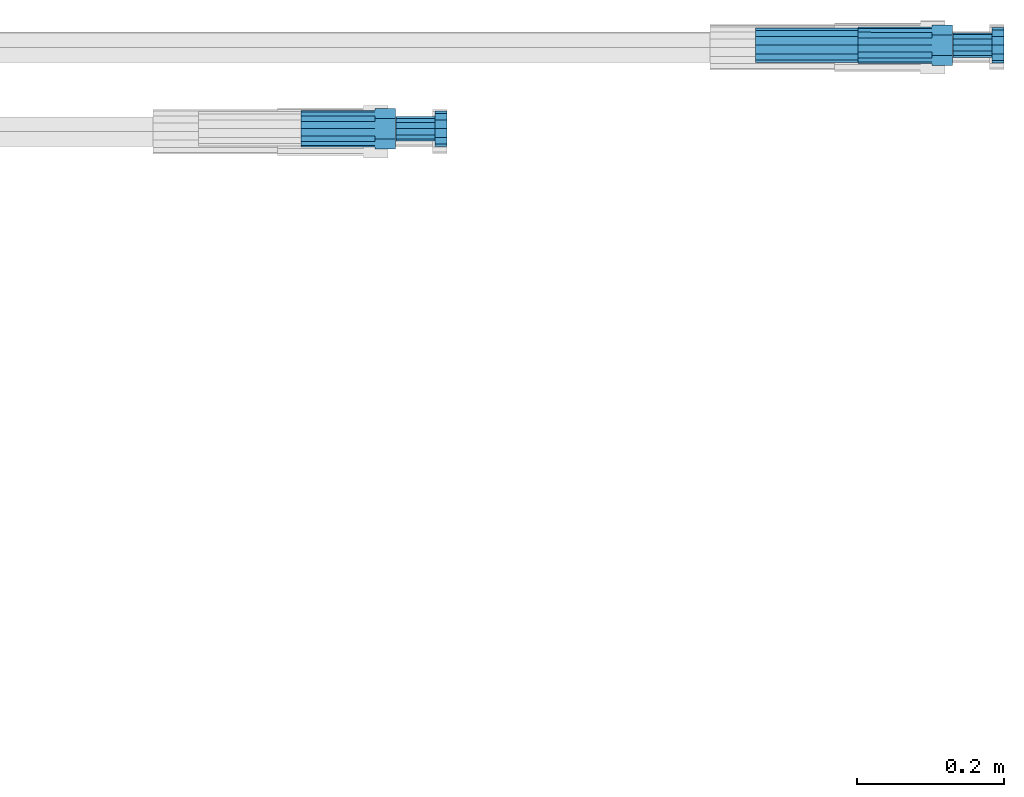
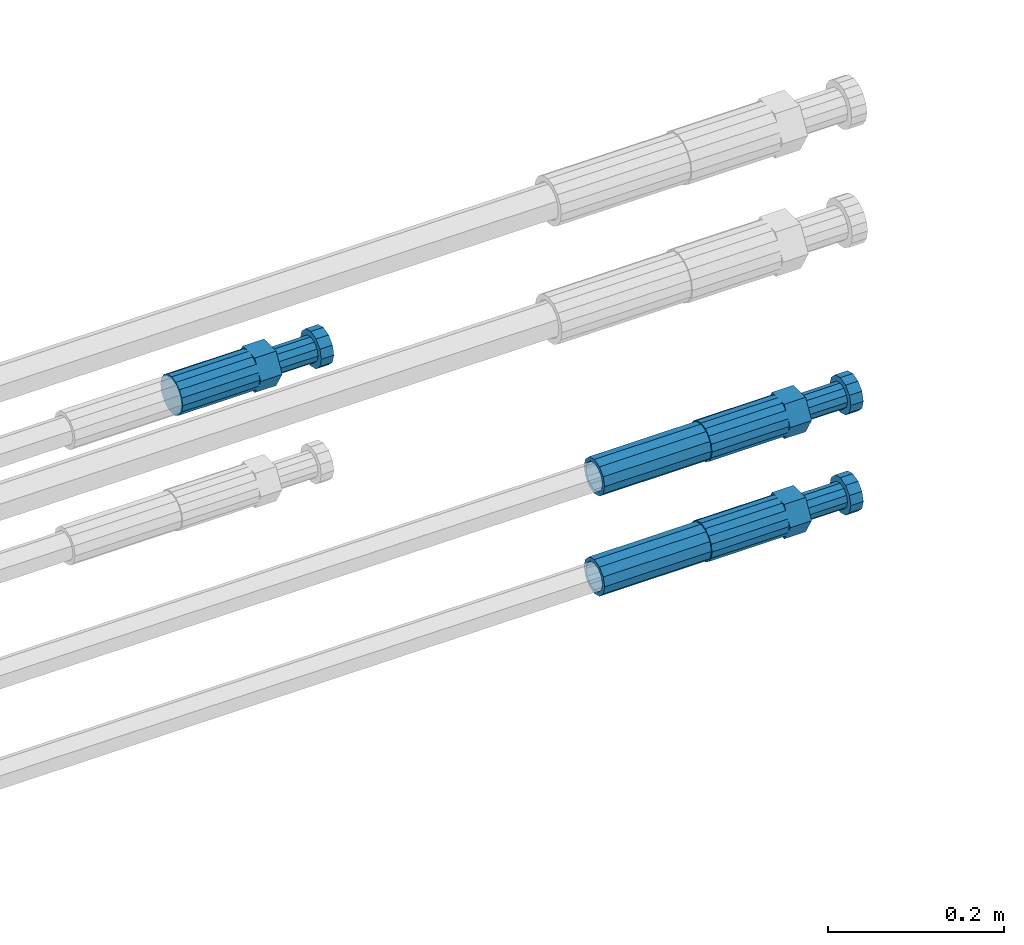
# One storey, part 110 of 119: 5 beams.
"""IFC2X3 building model written with IfcOpenShell, lengths in millimetres."""

from ifc_helpers import new_model, si_unit, frame, origin_with_axes, place, context, subcontext, project, spatial, faceted_brep, material, type_object, element, save


model = new_model("IFC2X3")

# Units and contexts
model_context = context("Model", 3, precision=1e-05, world=origin_with_axes())
body_context = subcontext(model_context, "Body", "Model", "MODEL_VIEW")
ifc_project = project(units=[si_unit("LENGTHUNIT", "METRE", prefix="MILLI"), si_unit("AREAUNIT", "SQUARE_METRE"), si_unit("VOLUMEUNIT", "CUBIC_METRE"), si_unit("MASSUNIT", "GRAM", prefix="KILO"), si_unit("TIMEUNIT", "SECOND"), si_unit("PLANEANGLEUNIT", "RADIAN"), si_unit("SOLIDANGLEUNIT", "STERADIAN"), si_unit("THERMODYNAMICTEMPERATUREUNIT", "DEGREE_CELSIUS"), si_unit("LUMINOUSINTENSITYUNIT", "LUMEN")], contexts=[model_context])

# Site, building, storey
site_placement = place(None, origin_with_axes())
site = spatial("IfcSite", under=ifc_project, at=site_placement, CompositionType="ELEMENT")
building_placement = place(site_placement, origin_with_axes())
building = spatial("IfcBuilding", under=site, at=building_placement, Name="Undefined", CompositionType="ELEMENT")
storey_placement = place(building_placement, origin_with_axes())
storey = spatial("IfcBuildingStorey", under=building, at=storey_placement, Name="Undefined", CompositionType="ELEMENT", Elevation=0.0)

# Beams
ifc_material = material(Name="STEEL/S275")
beam_type_1 = type_object("IfcBeamType", PredefinedType="NOTDEFINED")
beam_1_placement = place(storey_placement, frame((2039411.00023304, 6206403.47994599, 18871.489412972), z_axis=(0.0, 0.0, 1.0), x_axis=(1.0, 0.0, 0.0)))
element("IfcBeam", 1, at=beam_1_placement, inside=storey, type_object=beam_type_1, material=ifc_material, Name="AG32N", context=body_context, shape_type="Brep", body=[
    faceted_brep([(1.39698386192322e-09, -18.4999999990687, 0.0), (1.16415321826935e-09, -16.0214699693024, 9.25), (140.000000001164, -16.0214699935168, 9.25), (140.000000001397, -18.5000000232831, 0.0), (6.98491930961609e-10, -9.24999999906868, 16.0214699700118), (140.000000000698, -9.25000002328306, 16.0214699700118), (2.3283064365387e-10, 9.31322574615479e-10, 18.5), (140.000000000233, -2.3283064365387e-08, 18.5), (-2.3283064365387e-10, 9.25000000093132, 16.0214699700118), (139.999999999767, 9.24999997671694, 16.0214699700118), (-6.98491930961609e-10, 16.0214699711651, 9.25), (139.999999999302, 16.0214699469507, 9.25), (-9.31322574615479e-10, 18.5000000009313, 0.0), (139.999999999069, 18.4999999767169, 0.0), (-6.98491930961609e-10, 16.0214699711651, -9.25), (139.999999999302, 16.0214699469507, -9.25), (-2.3283064365387e-10, 9.25000000093132, -16.0214699700118), (139.999999999767, 9.24999997671694, -16.0214699700118), (2.3283064365387e-10, 9.31322574615479e-10, -18.5), (140.000000000233, -2.3283064365387e-08, -18.5), (6.98491930961609e-10, -9.24999999906868, -16.0214699700118), (140.000000000698, -9.25000002328306, -16.0214699700118), (1.16415321826935e-09, -16.0214699693024, -9.25), (140.000000001164, -16.0214699935168, -9.25), (1.62981450557709e-09, -23.4999999990687, 0.0), (1.39698386192322e-09, -20.3515969878063, -11.75), (140.000000001397, -20.3515970120206, -11.75), (140.00000000163, -23.5000000232831, 0.0), (9.31322574615479e-10, -11.7499999990687, -20.351596988934), (140.000000000931, -11.7500000232831, -20.351596988934), (2.3283064365387e-10, 9.31322574615479e-10, -23.5), (140.000000000233, -2.3283064365387e-08, -23.5), (-4.65661287307739e-10, 11.7500000009313, -20.351596988934), (139.999999999534, 11.7499999767169, -20.351596988934), (-9.31322574615479e-10, 20.3515969896689, -11.75), (139.999999999069, 20.3515969654545, -11.75), (-1.16415321826935e-09, 23.5000000009313, 0.0), (139.999999998836, 23.4999999767169, 0.0), (-9.31322574615479e-10, 20.3515969896689, 11.75), (139.999999999069, 20.3515969654545, 11.75), (-4.65661287307739e-10, 11.7500000009313, 20.351596988934), (139.999999999534, 11.7499999767169, 20.351596988934), (2.3283064365387e-10, 9.31322574615479e-10, 23.5), (140.000000000233, -2.3283064365387e-08, 23.5), (9.31322574615479e-10, -11.7499999990687, 20.351596988934), (140.000000000931, -11.7500000232831, 20.351596988934), (1.39698386192322e-09, -20.3515969878063, 11.75), (140.000000001397, -20.3515970120206, 11.75)], [[[0, 1, 2, 3]], [[1, 4, 5, 2]], [[4, 6, 7, 5]], [[6, 8, 9, 7]], [[8, 10, 11, 9]], [[10, 12, 13, 11]], [[12, 14, 15, 13]], [[14, 16, 17, 15]], [[16, 18, 19, 17]], [[18, 20, 21, 19]], [[20, 22, 23, 21]], [[22, 0, 3, 23]], [[24, 25, 26, 27]], [[25, 28, 29, 26]], [[28, 30, 31, 29]], [[30, 32, 33, 31]], [[32, 34, 35, 33]], [[34, 36, 37, 35]], [[36, 38, 39, 37]], [[38, 40, 41, 39]], [[40, 42, 43, 41]], [[42, 44, 45, 43]], [[44, 46, 47, 45]], [[46, 24, 27, 47]], [[29, 31, 33, 35, 37, 39, 41, 43, 45, 47, 27, 26], [5, 7, 9, 11, 13, 15, 17, 19, 21, 23, 3, 2]], [[46, 44, 42, 40, 38, 36, 34, 32, 30, 28, 25, 24], [22, 20, 18, 16, 14, 12, 10, 8, 6, 4, 1, 0]]]),
])
beam_2_placement = place(storey_placement, frame((2039411.00023304, 6206403.47994599, 19010.269412972), z_axis=(0.0, 0.0, 1.0), x_axis=(1.0, 0.0, 0.0)))
element("IfcBeam", 2, at=beam_2_placement, inside=storey, type_object=beam_type_1, material=ifc_material, Name="AG32N", context=body_context, shape_type="Brep", body=[
    faceted_brep([(1.39698386192322e-09, -18.4999999990687, 0.0), (1.16415321826935e-09, -16.0214699693024, 9.25), (140.000000001164, -16.0214699935168, 9.25), (140.000000001397, -18.5000000232831, 0.0), (6.98491930961609e-10, -9.24999999906868, 16.0214699700118), (140.000000000698, -9.25000002328306, 16.0214699700118), (2.3283064365387e-10, 9.31322574615479e-10, 18.5), (140.000000000233, -2.3283064365387e-08, 18.5), (-2.3283064365387e-10, 9.25000000093132, 16.0214699700118), (139.999999999767, 9.24999997671694, 16.0214699700118), (-6.98491930961609e-10, 16.0214699711651, 9.25), (139.999999999302, 16.0214699469507, 9.25), (-9.31322574615479e-10, 18.5000000009313, 0.0), (139.999999999069, 18.4999999767169, 0.0), (-6.98491930961609e-10, 16.0214699711651, -9.25), (139.999999999302, 16.0214699469507, -9.25), (-2.3283064365387e-10, 9.25000000093132, -16.0214699700118), (139.999999999767, 9.24999997671694, -16.0214699700118), (2.3283064365387e-10, 9.31322574615479e-10, -18.5), (140.000000000233, -2.3283064365387e-08, -18.5), (6.98491930961609e-10, -9.24999999906868, -16.0214699700118), (140.000000000698, -9.25000002328306, -16.0214699700118), (1.16415321826935e-09, -16.0214699693024, -9.25), (140.000000001164, -16.0214699935168, -9.25), (1.62981450557709e-09, -23.4999999990687, 0.0), (1.39698386192322e-09, -20.3515969878063, -11.75), (140.000000001397, -20.3515970120206, -11.75), (140.00000000163, -23.5000000232831, 0.0), (9.31322574615479e-10, -11.7499999990687, -20.351596988934), (140.000000000931, -11.7500000232831, -20.351596988934), (2.3283064365387e-10, 9.31322574615479e-10, -23.5), (140.000000000233, -2.3283064365387e-08, -23.5), (-4.65661287307739e-10, 11.7500000009313, -20.351596988934), (139.999999999534, 11.7499999767169, -20.351596988934), (-9.31322574615479e-10, 20.3515969896689, -11.75), (139.999999999069, 20.3515969654545, -11.75), (-1.16415321826935e-09, 23.5000000009313, 0.0), (139.999999998836, 23.4999999767169, 0.0), (-9.31322574615479e-10, 20.3515969896689, 11.75), (139.999999999069, 20.3515969654545, 11.75), (-4.65661287307739e-10, 11.7500000009313, 20.351596988934), (139.999999999534, 11.7499999767169, 20.351596988934), (2.3283064365387e-10, 9.31322574615479e-10, 23.5), (140.000000000233, -2.3283064365387e-08, 23.5), (9.31322574615479e-10, -11.7499999990687, 20.351596988934), (140.000000000931, -11.7500000232831, 20.351596988934), (1.39698386192322e-09, -20.3515969878063, 11.75), (140.000000001397, -20.3515970120206, 11.75)], [[[0, 1, 2, 3]], [[1, 4, 5, 2]], [[4, 6, 7, 5]], [[6, 8, 9, 7]], [[8, 10, 11, 9]], [[10, 12, 13, 11]], [[12, 14, 15, 13]], [[14, 16, 17, 15]], [[16, 18, 19, 17]], [[18, 20, 21, 19]], [[20, 22, 23, 21]], [[22, 0, 3, 23]], [[24, 25, 26, 27]], [[25, 28, 29, 26]], [[28, 30, 31, 29]], [[30, 32, 33, 31]], [[32, 34, 35, 33]], [[34, 36, 37, 35]], [[36, 38, 39, 37]], [[38, 40, 41, 39]], [[40, 42, 43, 41]], [[42, 44, 45, 43]], [[44, 46, 47, 45]], [[46, 24, 27, 47]], [[29, 31, 33, 35, 37, 39, 41, 43, 45, 47, 27, 26], [5, 7, 9, 11, 13, 15, 17, 19, 21, 23, 3, 2]], [[46, 44, 42, 40, 38, 36, 34, 32, 30, 28, 25, 24], [22, 20, 18, 16, 14, 12, 10, 8, 6, 4, 1, 0]]]),
])
beam_type_2 = type_object("IfcBeamType", Name="ROD50", PredefinedType="NOTDEFINED")
beam_3_placement = place(storey_placement, frame((2038791.00023304, 6206289.47994599, 19409.489419125), z_axis=(0.0, 0.0, 1.0), x_axis=(1.0, 0.0, 0.0)))
element("IfcBeam", 3, at=beam_3_placement, inside=storey, type_object=beam_type_2, material=ifc_material, Name="AGB32", ObjectType="ROD50", context=body_context, shape_type="Brep", body=[
    faceted_brep([(100.999999995111, 13.8425000002608, 23.9759132212093), (100.999999996508, 17.5285119004548, 17.5915533324223), (100.999999997672, 9.56708580907434, 23.0969883129546), (100.999999995111, 5.14843190740794, 23.9759132212093), (100.999999995111, -13.8425000002608, 23.9759132212093), (129.099999995669, -13.8425000002608, 23.9759132182917), (129.099999995669, 13.8425000002608, 23.9759132182917), (100.999999995111, -5.14843190740794, 23.9759132212093), (100.999999996508, -17.5285119004548, 17.5915533324223), (100.999999997672, -9.56708580907434, 23.0969883129546), (101.000000000233, -27.6849999995902, -8.25639290269464e-08), (129.100000000792, -27.6849999995902, -8.5481588030234e-08), (100.999999998836, -23.5887256683782, 7.09495518143376), (101.00000000163, -23.5887256180868, -7.09495543353478), (101.000000000233, -25.0, 1.70985003933311e-10), (101.000000005355, -13.8425000002608, -23.9759133863372), (129.100000005914, -13.8425000002608, -23.9759133892549), (101.000000003958, -17.5285119721666, -17.5915533734478), (101.000000005355, -5.14843107573688, -23.9759133863372), (101.000000002561, -9.56708580907434, -23.0969883126127), (101.000000005355, 13.8425000002608, -23.9759133863372), (129.100000005914, 13.8425000002608, -23.9759133892549), (101.000000005355, 5.14843107573688, -23.9759133863372), (101.000000002561, 9.56708580907434, -23.0969883126127), (101.000000003958, 17.5285119721666, -17.5915533734478), (101.000000000233, 27.6849999995902, -8.25639290269464e-08), (129.100000000792, 27.6849999995902, -8.5481588030234e-08), (101.00000000163, 23.5887256180868, -7.09495543353478), (101.000000000233, 25.0, 1.70985003933311e-10), (100.999999998836, 23.5887256683782, 7.09495518143376), (-6.98491930961609e-10, -23.0969883129001, 9.56708580912891), (-1.62981450557709e-09, -17.6776695298031, 17.6776695296649), (-2.3283064365387e-09, -9.56708580907434, 23.0969883127837), (-2.56113708019257e-09, 0.0, 25.0), (-2.3283064365387e-09, 9.56708580907434, 23.0969883127837), (-1.62981450557709e-09, 17.6776695298031, 17.6776695296649), (-6.98491930961609e-10, 23.0969883129001, 9.56708580912891), (2.3283064365387e-10, 25.0, 0.0), (1.16415321826935e-09, 23.0969883129001, -9.56708580912891), (2.09547579288483e-09, 17.6776695298031, -17.6776695296649), (2.56113708019257e-09, 9.56708580907434, -23.0969883127837), (2.79396772384644e-09, 0.0, -25.0), (2.56113708019257e-09, -9.56708580907434, -23.0969883127837), (2.09547579288483e-09, -17.6776695298031, -17.6776695296649), (1.16415321826935e-09, -23.0969883129001, -9.56708580912891), (2.3283064365387e-10, -25.0, 0.0), (100.999999999302, 23.0969883129001, 9.5670858092999), (101.000000001164, 23.0969883129001, -9.56708580895793), (101.000000002794, 0.0, -24.999999999829), (101.000000001164, -23.0969883129001, -9.56708580895793), (100.999999999302, -23.0969883129001, 9.5670858092999), (100.999999997439, 0.0, 25.000000000171), (129.49999999837, -14.2894191620871, 8.24999989414209), (129.499999996973, -8.25, 14.2894190565821), (129.49999999674, 0.0, 16.4999998941421), (129.499999996973, 8.25, 14.2894190565821), (129.49999999837, 14.2894191620871, 8.24999989414209), (129.500000000233, 16.5, -1.05857907328755e-07), (129.500000002095, 14.2894191620871, -8.25000010585791), (129.50000000326, 8.25, -14.2894192683016), (129.500000003492, 0.0, -16.5000001058615), (129.50000000326, -8.25, -14.2894192683016), (129.500000002095, -14.2894191620871, -8.25000010586155), (129.500000000233, -16.5, -1.05857907328755e-07), (182.499999996973, 8.25, 14.2894190510815), (182.49999999674, 0.0, 16.4999998886415), (182.49999999837, 14.2894191620871, 8.24999988864147), (182.500000000233, 16.5, -1.11358531285077e-07), (182.500000002095, 14.2894191620871, -8.25000011135853), (182.50000000326, 8.25, -14.2894192738022), (182.500000003492, 0.0, -16.5000001113622), (182.50000000326, -8.25, -14.2894192738022), (182.500000002095, -14.2894191620871, -8.25000011136217), (182.500000000233, -16.5, -1.11358531285077e-07), (182.49999999837, -14.2894191620871, 8.24999988864147), (182.499999996973, -8.25, 14.2894190510815), (182.500000002561, -20.7846096912399, -12.0000001491826), (182.500000004657, -12.0, -20.7846098400078), (199.000000004657, -12.0, -20.7846098417212), (199.000000002561, -20.7846096912399, -12.0000001508961), (182.500000005355, 0.0, -24.0000001491826), (199.000000005355, 0.0, -24.0000001508961), (182.500000004657, 12.0, -20.7846098400078), (199.000000004657, 12.0, -20.7846098417212), (182.500000002561, 20.7846096912399, -12.000000149179), (199.000000002561, 20.7846096912399, -12.0000001508924), (182.500000000233, 24.0, -1.49178958963603e-07), (199.000000000233, 24.0, -1.50892446981743e-07), (182.499999997672, 20.7846096912399, 11.999999850821), (198.999999997672, 20.7846096912399, 11.9999998491076), (182.499999995809, 12.0, 20.7846095416462), (198.999999995809, 12.0, 20.7846095399327), (182.499999995111, 0.0, 23.999999850821), (198.999999995111, 0.0, 23.9999998491076), (182.499999995809, -12.0, 20.7846095416462), (198.999999995809, -12.0, 20.7846095399327), (182.499999997672, -20.7846096912399, 11.999999850821), (198.999999997672, -20.7846096912399, 11.9999998491039), (182.500000000233, -24.0, -1.49178958963603e-07), (199.000000000233, -24.0, -1.50892446981743e-07)], [[[0, 1, 2, 3]], [[4, 5, 6, 0, 3, 7]], [[8, 4, 7, 9]], [[10, 11, 5, 4, 8, 12]], [[13, 10, 12, 14]], [[15, 16, 11, 10, 13, 17]], [[18, 15, 17, 19]], [[20, 21, 16, 15, 18, 22]], [[20, 22, 23, 24]], [[25, 26, 21, 20, 24, 27]], [[25, 27, 28, 29]], [[30, 31, 32, 33, 34, 35, 36, 37, 38, 39, 40, 41, 42, 43, 44, 45]], [[28, 37, 36, 46, 29]], [[27, 47, 38, 37, 28]], [[24, 47, 27]], [[39, 38, 47, 24]], [[23, 40, 39, 24]], [[22, 48, 41, 40, 23]], [[18, 48, 22]], [[19, 42, 41, 48, 18]], [[17, 43, 42, 19]], [[44, 43, 17, 49]], [[13, 49, 17]], [[14, 45, 44, 49, 13]], [[12, 50, 30, 45, 14]], [[8, 50, 12]], [[31, 30, 50, 8]], [[9, 32, 31, 8]], [[7, 51, 33, 32, 9]], [[3, 51, 7]], [[2, 34, 33, 51, 3]], [[1, 35, 34, 2]], [[36, 35, 1, 46]], [[29, 46, 1]], [[0, 6, 26, 25, 29, 1]], [[5, 11, 16, 21, 26, 6]], [[52, 53, 54, 55, 56, 57, 58, 59, 60, 61, 62, 63]], [[64, 55, 54, 65]], [[66, 56, 55, 64]], [[67, 57, 56, 66]], [[68, 58, 57, 67]], [[69, 59, 58, 68]], [[70, 60, 59, 69]], [[71, 61, 60, 70]], [[72, 62, 61, 71]], [[73, 63, 62, 72]], [[74, 52, 63, 73]], [[75, 53, 52, 74]], [[65, 54, 53, 75]], [[76, 77, 78, 79]], [[77, 80, 81, 78]], [[80, 82, 83, 81]], [[82, 84, 85, 83]], [[84, 86, 87, 85]], [[86, 88, 89, 87]], [[88, 90, 91, 89]], [[90, 92, 93, 91]], [[92, 94, 95, 93]], [[94, 96, 97, 95]], [[96, 98, 99, 97]], [[78, 81, 83, 85, 87, 89, 91, 93, 95, 97, 99, 79]], [[98, 76, 79, 99]], [[96, 94, 92, 90, 88, 86, 84, 82, 80, 77, 76, 98], [74, 73, 72, 71, 70, 69, 68, 67, 66, 64, 65, 75]]]),
])
beam_4_placement = place(storey_placement, frame((2039551.00023304, 6206403.47994599, 18871.4894149922), z_axis=(0.0, 0.0, 1.0), x_axis=(1.0, 0.0, 0.0)))
element("IfcBeam", 4, at=beam_4_placement, inside=storey, type_object=beam_type_2, material=ifc_material, Name="AGB32", ObjectType="ROD50", context=body_context, shape_type="Brep", body=[
    faceted_brep([(100.999999995111, 13.8425000002608, 23.9759132212093), (100.999999996508, 17.5285119004548, 17.5915533324223), (100.999999997672, 9.56708580907434, 23.0969883129546), (100.999999995111, 5.14843190740794, 23.9759132212093), (100.999999995111, -13.8425000002608, 23.9759132212093), (129.099999995669, -13.8425000002608, 23.9759132182917), (129.099999995669, 13.8425000002608, 23.9759132182917), (100.999999995111, -5.14843190740794, 23.9759132212093), (100.999999996508, -17.5285119004548, 17.5915533324223), (100.999999997672, -9.56708580907434, 23.0969883129546), (101.000000000233, -27.6849999995902, -8.25639290269464e-08), (129.100000000792, -27.6849999995902, -8.5481588030234e-08), (100.999999998836, -23.5887256683782, 7.09495518143376), (101.00000000163, -23.5887256180868, -7.09495543353478), (101.000000000233, -25.0, 1.70985003933311e-10), (101.000000005355, -13.8425000002608, -23.9759133863372), (129.100000005914, -13.8425000002608, -23.9759133892549), (101.000000003958, -17.5285119721666, -17.5915533734478), (101.000000005355, -5.14843107573688, -23.9759133863372), (101.000000002561, -9.56708580907434, -23.0969883126127), (101.000000005355, 13.8425000002608, -23.9759133863372), (129.100000005914, 13.8425000002608, -23.9759133892549), (101.000000005355, 5.14843107573688, -23.9759133863372), (101.000000002561, 9.56708580907434, -23.0969883126127), (101.000000003958, 17.5285119721666, -17.5915533734478), (101.000000000233, 27.6849999995902, -8.25639290269464e-08), (129.100000000792, 27.6849999995902, -8.5481588030234e-08), (101.00000000163, 23.5887256180868, -7.09495543353478), (101.000000000233, 25.0, 1.70985003933311e-10), (100.999999998836, 23.5887256683782, 7.09495518143376), (-6.98491930961609e-10, -23.0969883129001, 9.56708580912891), (-1.62981450557709e-09, -17.6776695298031, 17.6776695296649), (-2.3283064365387e-09, -9.56708580907434, 23.0969883127837), (-2.56113708019257e-09, 0.0, 25.0), (-2.3283064365387e-09, 9.56708580907434, 23.0969883127837), (-1.62981450557709e-09, 17.6776695298031, 17.6776695296649), (-6.98491930961609e-10, 23.0969883129001, 9.56708580912891), (2.3283064365387e-10, 25.0, 0.0), (1.16415321826935e-09, 23.0969883129001, -9.56708580912891), (2.09547579288483e-09, 17.6776695298031, -17.6776695296649), (2.56113708019257e-09, 9.56708580907434, -23.0969883127837), (2.79396772384644e-09, 0.0, -25.0), (2.56113708019257e-09, -9.56708580907434, -23.0969883127837), (2.09547579288483e-09, -17.6776695298031, -17.6776695296649), (1.16415321826935e-09, -23.0969883129001, -9.56708580912891), (2.3283064365387e-10, -25.0, 0.0), (100.999999999302, 23.0969883129001, 9.5670858092999), (101.000000001164, 23.0969883129001, -9.56708580895793), (101.000000002794, 0.0, -24.999999999829), (101.000000001164, -23.0969883129001, -9.56708580895793), (100.999999999302, -23.0969883129001, 9.5670858092999), (100.999999997439, 0.0, 25.000000000171), (129.49999999837, -14.2894191620871, 8.24999989414209), (129.499999996973, -8.25, 14.2894190565821), (129.49999999674, 0.0, 16.4999998941421), (129.499999996973, 8.25, 14.2894190565821), (129.49999999837, 14.2894191620871, 8.24999989414209), (129.500000000233, 16.5, -1.05857907328755e-07), (129.500000002095, 14.2894191620871, -8.25000010585791), (129.50000000326, 8.25, -14.2894192683016), (129.500000003492, 0.0, -16.5000001058615), (129.50000000326, -8.25, -14.2894192683016), (129.500000002095, -14.2894191620871, -8.25000010586155), (129.500000000233, -16.5, -1.05857907328755e-07), (182.499999996973, 8.25, 14.2894190510815), (182.49999999674, 0.0, 16.4999998886415), (182.49999999837, 14.2894191620871, 8.24999988864147), (182.500000000233, 16.5, -1.11358531285077e-07), (182.500000002095, 14.2894191620871, -8.25000011135853), (182.50000000326, 8.25, -14.2894192738022), (182.500000003492, 0.0, -16.5000001113622), (182.50000000326, -8.25, -14.2894192738022), (182.500000002095, -14.2894191620871, -8.25000011136217), (182.500000000233, -16.5, -1.11358531285077e-07), (182.49999999837, -14.2894191620871, 8.24999988864147), (182.499999996973, -8.25, 14.2894190510815), (182.500000002561, -20.7846096912399, -12.0000001491826), (182.500000004657, -12.0, -20.7846098400078), (199.000000004657, -12.0, -20.7846098417212), (199.000000002561, -20.7846096912399, -12.0000001508961), (182.500000005355, 0.0, -24.0000001491826), (199.000000005355, 0.0, -24.0000001508961), (182.500000004657, 12.0, -20.7846098400078), (199.000000004657, 12.0, -20.7846098417212), (182.500000002561, 20.7846096912399, -12.000000149179), (199.000000002561, 20.7846096912399, -12.0000001508924), (182.500000000233, 24.0, -1.49178958963603e-07), (199.000000000233, 24.0, -1.50892446981743e-07), (182.499999997672, 20.7846096912399, 11.999999850821), (198.999999997672, 20.7846096912399, 11.9999998491076), (182.499999995809, 12.0, 20.7846095416462), (198.999999995809, 12.0, 20.7846095399327), (182.499999995111, 0.0, 23.999999850821), (198.999999995111, 0.0, 23.9999998491076), (182.499999995809, -12.0, 20.7846095416462), (198.999999995809, -12.0, 20.7846095399327), (182.499999997672, -20.7846096912399, 11.999999850821), (198.999999997672, -20.7846096912399, 11.9999998491039), (182.500000000233, -24.0, -1.49178958963603e-07), (199.000000000233, -24.0, -1.50892446981743e-07)], [[[0, 1, 2, 3]], [[4, 5, 6, 0, 3, 7]], [[8, 4, 7, 9]], [[10, 11, 5, 4, 8, 12]], [[13, 10, 12, 14]], [[15, 16, 11, 10, 13, 17]], [[18, 15, 17, 19]], [[20, 21, 16, 15, 18, 22]], [[20, 22, 23, 24]], [[25, 26, 21, 20, 24, 27]], [[25, 27, 28, 29]], [[30, 31, 32, 33, 34, 35, 36, 37, 38, 39, 40, 41, 42, 43, 44, 45]], [[28, 37, 36, 46, 29]], [[27, 47, 38, 37, 28]], [[24, 47, 27]], [[39, 38, 47, 24]], [[23, 40, 39, 24]], [[22, 48, 41, 40, 23]], [[18, 48, 22]], [[19, 42, 41, 48, 18]], [[17, 43, 42, 19]], [[44, 43, 17, 49]], [[13, 49, 17]], [[14, 45, 44, 49, 13]], [[12, 50, 30, 45, 14]], [[8, 50, 12]], [[31, 30, 50, 8]], [[9, 32, 31, 8]], [[7, 51, 33, 32, 9]], [[3, 51, 7]], [[2, 34, 33, 51, 3]], [[1, 35, 34, 2]], [[36, 35, 1, 46]], [[29, 46, 1]], [[0, 6, 26, 25, 29, 1]], [[5, 11, 16, 21, 26, 6]], [[52, 53, 54, 55, 56, 57, 58, 59, 60, 61, 62, 63]], [[64, 55, 54, 65]], [[66, 56, 55, 64]], [[67, 57, 56, 66]], [[68, 58, 57, 67]], [[69, 59, 58, 68]], [[70, 60, 59, 69]], [[71, 61, 60, 70]], [[72, 62, 61, 71]], [[73, 63, 62, 72]], [[74, 52, 63, 73]], [[75, 53, 52, 74]], [[65, 54, 53, 75]], [[76, 77, 78, 79]], [[77, 80, 81, 78]], [[80, 82, 83, 81]], [[82, 84, 85, 83]], [[84, 86, 87, 85]], [[86, 88, 89, 87]], [[88, 90, 91, 89]], [[90, 92, 93, 91]], [[92, 94, 95, 93]], [[94, 96, 97, 95]], [[96, 98, 99, 97]], [[78, 81, 83, 85, 87, 89, 91, 93, 95, 97, 99, 79]], [[98, 76, 79, 99]], [[96, 94, 92, 90, 88, 86, 84, 82, 80, 77, 76, 98], [74, 73, 72, 71, 70, 69, 68, 67, 66, 64, 65, 75]]]),
])
beam_5_placement = place(storey_placement, frame((2039551.00023304, 6206403.47994599, 19010.2694149922), z_axis=(0.0, 0.0, 1.0), x_axis=(1.0, 0.0, 0.0)))
element("IfcBeam", 5, at=beam_5_placement, inside=storey, type_object=beam_type_2, material=ifc_material, Name="AGB32", ObjectType="ROD50", context=body_context, shape_type="Brep", body=[
    faceted_brep([(100.999999995111, 13.8425000002608, 23.9759132212093), (100.999999996508, 17.5285119004548, 17.5915533324223), (100.999999997672, 9.56708580907434, 23.0969883129546), (100.999999995111, 5.14843190740794, 23.9759132212093), (100.999999995111, -13.8425000002608, 23.9759132212093), (129.099999995669, -13.8425000002608, 23.9759132182917), (129.099999995669, 13.8425000002608, 23.9759132182917), (100.999999995111, -5.14843190740794, 23.9759132212093), (100.999999996508, -17.5285119004548, 17.5915533324223), (100.999999997672, -9.56708580907434, 23.0969883129546), (101.000000000233, -27.6849999995902, -8.25639290269464e-08), (129.100000000792, -27.6849999995902, -8.5481588030234e-08), (100.999999998836, -23.5887256683782, 7.09495518143376), (101.00000000163, -23.5887256180868, -7.09495543353478), (101.000000000233, -25.0, 1.70985003933311e-10), (101.000000005355, -13.8425000002608, -23.9759133863372), (129.100000005914, -13.8425000002608, -23.9759133892549), (101.000000003958, -17.5285119721666, -17.5915533734478), (101.000000005355, -5.14843107573688, -23.9759133863372), (101.000000002561, -9.56708580907434, -23.0969883126127), (101.000000005355, 13.8425000002608, -23.9759133863372), (129.100000005914, 13.8425000002608, -23.9759133892549), (101.000000005355, 5.14843107573688, -23.9759133863372), (101.000000002561, 9.56708580907434, -23.0969883126127), (101.000000003958, 17.5285119721666, -17.5915533734478), (101.000000000233, 27.6849999995902, -8.25639290269464e-08), (129.100000000792, 27.6849999995902, -8.5481588030234e-08), (101.00000000163, 23.5887256180868, -7.09495543353478), (101.000000000233, 25.0, 1.70985003933311e-10), (100.999999998836, 23.5887256683782, 7.09495518143376), (-6.98491930961609e-10, -23.0969883129001, 9.56708580912891), (-1.62981450557709e-09, -17.6776695298031, 17.6776695296649), (-2.3283064365387e-09, -9.56708580907434, 23.0969883127837), (-2.56113708019257e-09, 0.0, 25.0), (-2.3283064365387e-09, 9.56708580907434, 23.0969883127837), (-1.62981450557709e-09, 17.6776695298031, 17.6776695296649), (-6.98491930961609e-10, 23.0969883129001, 9.56708580912891), (2.3283064365387e-10, 25.0, 0.0), (1.16415321826935e-09, 23.0969883129001, -9.56708580912891), (2.09547579288483e-09, 17.6776695298031, -17.6776695296649), (2.56113708019257e-09, 9.56708580907434, -23.0969883127837), (2.79396772384644e-09, 0.0, -25.0), (2.56113708019257e-09, -9.56708580907434, -23.0969883127837), (2.09547579288483e-09, -17.6776695298031, -17.6776695296649), (1.16415321826935e-09, -23.0969883129001, -9.56708580912891), (2.3283064365387e-10, -25.0, 0.0), (100.999999999302, 23.0969883129001, 9.5670858092999), (101.000000001164, 23.0969883129001, -9.56708580895793), (101.000000002794, 0.0, -24.999999999829), (101.000000001164, -23.0969883129001, -9.56708580895793), (100.999999999302, -23.0969883129001, 9.5670858092999), (100.999999997439, 0.0, 25.000000000171), (129.49999999837, -14.2894191620871, 8.24999989414209), (129.499999996973, -8.25, 14.2894190565821), (129.49999999674, 0.0, 16.4999998941421), (129.499999996973, 8.25, 14.2894190565821), (129.49999999837, 14.2894191620871, 8.24999989414209), (129.500000000233, 16.5, -1.05857907328755e-07), (129.500000002095, 14.2894191620871, -8.25000010585791), (129.50000000326, 8.25, -14.2894192683016), (129.500000003492, 0.0, -16.5000001058615), (129.50000000326, -8.25, -14.2894192683016), (129.500000002095, -14.2894191620871, -8.25000010586155), (129.500000000233, -16.5, -1.05857907328755e-07), (182.499999996973, 8.25, 14.2894190510815), (182.49999999674, 0.0, 16.4999998886415), (182.49999999837, 14.2894191620871, 8.24999988864147), (182.500000000233, 16.5, -1.11358531285077e-07), (182.500000002095, 14.2894191620871, -8.25000011135853), (182.50000000326, 8.25, -14.2894192738022), (182.500000003492, 0.0, -16.5000001113622), (182.50000000326, -8.25, -14.2894192738022), (182.500000002095, -14.2894191620871, -8.25000011136217), (182.500000000233, -16.5, -1.11358531285077e-07), (182.49999999837, -14.2894191620871, 8.24999988864147), (182.499999996973, -8.25, 14.2894190510815), (182.500000002561, -20.7846096912399, -12.0000001491826), (182.500000004657, -12.0, -20.7846098400078), (199.000000004657, -12.0, -20.7846098417212), (199.000000002561, -20.7846096912399, -12.0000001508961), (182.500000005355, 0.0, -24.0000001491826), (199.000000005355, 0.0, -24.0000001508961), (182.500000004657, 12.0, -20.7846098400078), (199.000000004657, 12.0, -20.7846098417212), (182.500000002561, 20.7846096912399, -12.000000149179), (199.000000002561, 20.7846096912399, -12.0000001508924), (182.500000000233, 24.0, -1.49178958963603e-07), (199.000000000233, 24.0, -1.50892446981743e-07), (182.499999997672, 20.7846096912399, 11.999999850821), (198.999999997672, 20.7846096912399, 11.9999998491076), (182.499999995809, 12.0, 20.7846095416462), (198.999999995809, 12.0, 20.7846095399327), (182.499999995111, 0.0, 23.999999850821), (198.999999995111, 0.0, 23.9999998491076), (182.499999995809, -12.0, 20.7846095416462), (198.999999995809, -12.0, 20.7846095399327), (182.499999997672, -20.7846096912399, 11.999999850821), (198.999999997672, -20.7846096912399, 11.9999998491039), (182.500000000233, -24.0, -1.49178958963603e-07), (199.000000000233, -24.0, -1.50892446981743e-07)], [[[0, 1, 2, 3]], [[4, 5, 6, 0, 3, 7]], [[8, 4, 7, 9]], [[10, 11, 5, 4, 8, 12]], [[13, 10, 12, 14]], [[15, 16, 11, 10, 13, 17]], [[18, 15, 17, 19]], [[20, 21, 16, 15, 18, 22]], [[20, 22, 23, 24]], [[25, 26, 21, 20, 24, 27]], [[25, 27, 28, 29]], [[30, 31, 32, 33, 34, 35, 36, 37, 38, 39, 40, 41, 42, 43, 44, 45]], [[28, 37, 36, 46, 29]], [[27, 47, 38, 37, 28]], [[24, 47, 27]], [[39, 38, 47, 24]], [[23, 40, 39, 24]], [[22, 48, 41, 40, 23]], [[18, 48, 22]], [[19, 42, 41, 48, 18]], [[17, 43, 42, 19]], [[44, 43, 17, 49]], [[13, 49, 17]], [[14, 45, 44, 49, 13]], [[12, 50, 30, 45, 14]], [[8, 50, 12]], [[31, 30, 50, 8]], [[9, 32, 31, 8]], [[7, 51, 33, 32, 9]], [[3, 51, 7]], [[2, 34, 33, 51, 3]], [[1, 35, 34, 2]], [[36, 35, 1, 46]], [[29, 46, 1]], [[0, 6, 26, 25, 29, 1]], [[5, 11, 16, 21, 26, 6]], [[52, 53, 54, 55, 56, 57, 58, 59, 60, 61, 62, 63]], [[64, 55, 54, 65]], [[66, 56, 55, 64]], [[67, 57, 56, 66]], [[68, 58, 57, 67]], [[69, 59, 58, 68]], [[70, 60, 59, 69]], [[71, 61, 60, 70]], [[72, 62, 61, 71]], [[73, 63, 62, 72]], [[74, 52, 63, 73]], [[75, 53, 52, 74]], [[65, 54, 53, 75]], [[76, 77, 78, 79]], [[77, 80, 81, 78]], [[80, 82, 83, 81]], [[82, 84, 85, 83]], [[84, 86, 87, 85]], [[86, 88, 89, 87]], [[88, 90, 91, 89]], [[90, 92, 93, 91]], [[92, 94, 95, 93]], [[94, 96, 97, 95]], [[96, 98, 99, 97]], [[78, 81, 83, 85, 87, 89, 91, 93, 95, 97, 99, 79]], [[98, 76, 79, 99]], [[96, 94, 92, 90, 88, 86, 84, 82, 80, 77, 76, 98], [74, 73, 72, 71, 70, 69, 68, 67, 66, 64, 65, 75]]]),
])

save(model, "model.ifc")
